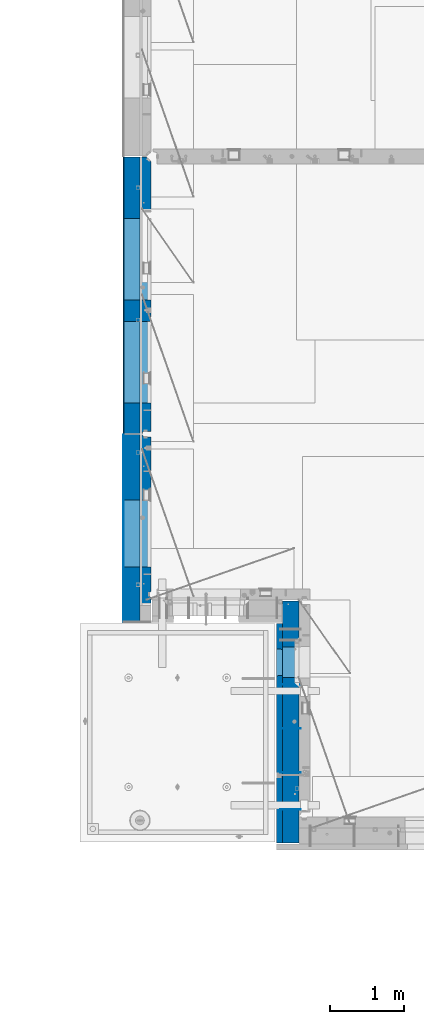
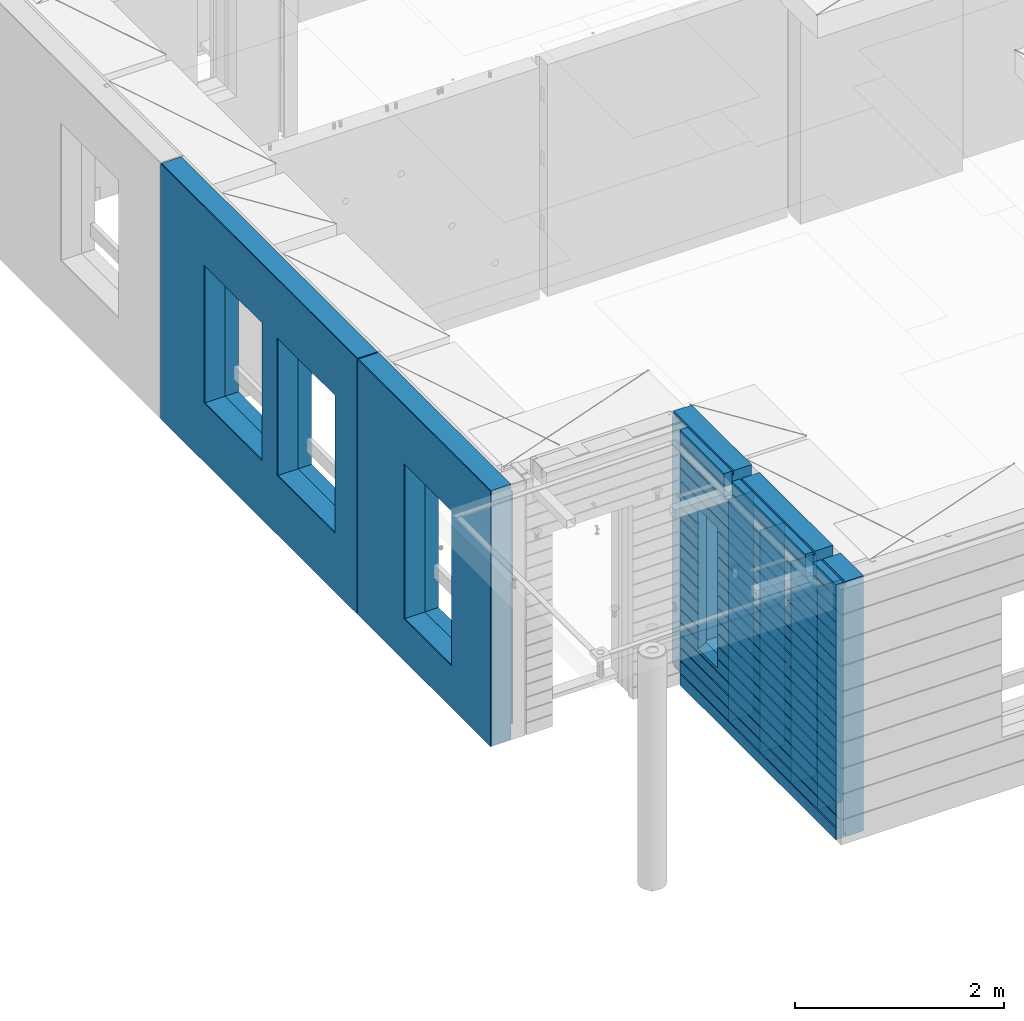
# One storey, part 228 of 350: 12 walls, 3 elements without a shape of their own.
"""IFC2X3 building model written with IfcOpenShell, lengths in millimetres."""

from ifc_helpers import new_model, si_unit, frame, origin_with_axes, place, context, subcontext, project, spatial, faceted_brep, material, type_object, element, aggregate, save


model = new_model("IFC2X3")

# Units and contexts
model_context = context("Model", 3, precision=1e-05, world=origin_with_axes())
body_context = subcontext(model_context, "Body", "Model", "MODEL_VIEW")
ifc_project = project(units=[si_unit("LENGTHUNIT", "METRE", prefix="MILLI"), si_unit("AREAUNIT", "SQUARE_METRE"), si_unit("VOLUMEUNIT", "CUBIC_METRE"), si_unit("MASSUNIT", "GRAM", prefix="KILO"), si_unit("TIMEUNIT", "SECOND"), si_unit("PLANEANGLEUNIT", "RADIAN"), si_unit("SOLIDANGLEUNIT", "STERADIAN"), si_unit("THERMODYNAMICTEMPERATUREUNIT", "DEGREE_CELSIUS"), si_unit("LUMINOUSINTENSITYUNIT", "LUMEN")], contexts=[model_context])

# Site, building, storey
site_placement = place(None, origin_with_axes())
site = spatial("IfcSite", under=ifc_project, at=site_placement, CompositionType="ELEMENT")
building_placement = place(site_placement, origin_with_axes())
building = spatial("IfcBuilding", under=site, at=building_placement, CompositionType="ELEMENT")
storey_placement = place(building_placement, origin_with_axes())
storey = spatial("IfcBuildingStorey", under=building, at=storey_placement, Name="2", CompositionType="ELEMENT", Elevation=0.0)

# Assembly, walls
assembly_1_placement = place(storey_placement, origin_with_axes())
assembly_1 = element("IfcElementAssembly", 1, at=assembly_1_placement, inside=storey, AssemblyPlace="NOTDEFINED", PredefinedType="REINFORCEMENT_UNIT")
ifc_material_1 = material(Name="Undefined")
wall_type_1 = type_object("IfcWallType", PredefinedType="NOTDEFINED")
wall_1_placement = place(assembly_1_placement, frame((10040.0, 8600.0, 86115.0), z_axis=(0.0, 0.0, 1.0), x_axis=(-1.0, 3.00000001838171e-08, 0.0)))
wall_1 = element("IfcWall", 2, at=wall_1_placement, type_object=wall_type_1, material=ifc_material_1, Name="(PD)", context=body_context, shape_type="Brep", body=[
    faceted_brep([(0.0, 5.0, -1300.0), (0.0, 5.0, 1300.0), (280.0, 5.0, 1300.0), (280.0, 5.0, -1300.0), (0.0, -5.0, 1300.0), (280.0, -5.0, 1300.0), (0.0, -5.0, -1300.0), (280.0, -5.0, -1300.0)], [[[0, 1, 2, 3]], [[1, 4, 5, 2]], [[4, 6, 7, 5]], [[6, 0, 3, 7]], [[5, 7, 3, 2]], [[6, 4, 1, 0]]]),
])
wall_2_placement = place(assembly_1_placement, frame((10040.0, 9200.0, 86115.0), z_axis=(0.0, 0.0, 1.0), x_axis=(-1.0, 3.00000001838171e-08, 0.0)))
wall_2 = element("IfcWall", 3, at=wall_2_placement, type_object=wall_type_1, material=ifc_material_1, Name="(PD)", context=body_context, shape_type="Brep", body=[
    faceted_brep([(0.0, 5.0, -1300.0), (0.0, 5.0, 1300.0), (280.0, 5.0, 1300.0), (280.0, 5.0, -1300.0), (0.0, -5.0, 1300.0), (280.0, -5.0, 1300.0), (0.0, -5.0, -1300.0), (280.0, -5.0, -1300.0)], [[[0, 1, 2, 3]], [[1, 4, 5, 2]], [[4, 6, 7, 5]], [[6, 0, 3, 7]], [[5, 7, 3, 2]], [[6, 4, 1, 0]]]),
])
wall_3_placement = place(assembly_1_placement, frame((10040.0, 8100.0, 86115.0), z_axis=(0.0, 0.0, 1.0), x_axis=(-1.0, 3.00000001838171e-08, 0.0)))
wall_3 = element("IfcWall", 4, at=wall_3_placement, type_object=wall_type_1, material=ifc_material_1, Name="(PD)", context=body_context, shape_type="Brep", body=[
    faceted_brep([(0.0, 5.0, -1300.0), (0.0, 5.0, 1300.0), (280.0, 5.0, 1300.0), (280.0, 5.0, -1300.0), (0.0, -5.0, 1300.0), (280.0, -5.0, 1300.0), (0.0, -5.0, -1300.0), (280.0, -5.0, -1300.0)], [[[0, 1, 2, 3]], [[1, 4, 5, 2]], [[4, 6, 7, 5]], [[6, 0, 3, 7]], [[5, 7, 3, 2]], [[6, 4, 1, 0]]]),
])
wall_4_placement = place(assembly_1_placement, frame((10040.0, 9800.0, 86115.0), z_axis=(0.0, 0.0, 1.0), x_axis=(-1.0, 3.00000001838171e-08, 0.0)))
wall_4 = element("IfcWall", 5, at=wall_4_placement, type_object=wall_type_1, material=ifc_material_1, Name="(PD)", context=body_context, shape_type="Brep", body=[
    faceted_brep([(0.0, 5.0, -1300.0), (0.0, 5.0, 1300.0), (280.0, 5.0, 1300.0), (280.0, 5.0, -1300.0), (0.0, -5.0, 1300.0), (280.0, -5.0, 1300.0), (0.0, -5.0, -1300.0), (280.0, -5.0, -1300.0)], [[[0, 1, 2, 3]], [[1, 4, 5, 2]], [[4, 6, 7, 5]], [[6, 0, 3, 7]], [[5, 7, 3, 2]], [[6, 4, 1, 0]]]),
])
ifc_material_2 = material(Name="COS5gt")
wall_type_2 = type_object("IfcWallType", PredefinedType="NOTDEFINED")
wall_5_placement = place(assembly_1_placement, frame((9900.0, 8000.0, 86247.5), z_axis=(0.0, 0.0, 1.0), x_axis=(0.0, 1.0, 0.0)))
wall_5 = element("IfcWall", 6, at=wall_5_placement, type_object=wall_type_2, material=ifc_material_2, context=body_context, shape_type="Brep", body=[
    faceted_brep([(2935.0, 90.0, 1492.5), (2935.0, 90.0, 1442.5), (1785.0, 90.0, 1442.5), (1785.0, 90.0, 1492.5), (2935.0, 110.0, 1442.5), (1785.0, 110.0, 1442.5), (1635.0, 90.0, 1442.5), (1635.0, 110.0, 1442.5), (229.999999999998, 110.0, 1442.5), (229.999999999998, 90.0, 1442.5), (1635.0, 90.0, 1492.5), (229.999999999998, 90.0, 1492.5), (1635.0, -110.0, 1492.5), (1635.0, -110.0, 1222.5), (1635.0, 110.0, 1222.5), (1785.0, -110.0, 1222.5), (1785.0, 110.0, 1222.5), (1785.0, -110.0, 1492.5), (2935.0, -110.0, 1492.5), (2935.0, -110.0, -1492.5), (-355.0, -110.0, -1492.5), (-355.0, 90.0, -1492.5), (2935.0, 90.0, -1492.5), (2935.0, 90.0, -1442.5), (2935.0, 110.0, -1442.5), (-355.0, 90.0, -1442.5), (-355.0, 110.0, -1442.5), (-355.0, -110.0, 1492.5), (-355.0, 90.0, 1492.5), (-355.0, 90.0, 1442.5), (-355.0, 110.0, 1442.5), (79.9999999999982, 90.0, 1442.5), (79.9999999999982, 110.0, 1442.5), (79.9999999999982, 110.0, 1222.5), (229.999999999998, 110.0, 1222.5), (1895.00042424099, 109.999999996904, -802.5), (1895.00042424099, 109.999999996904, -807.5), (1925.00042424099, 109.999999996904, -807.5), (2275.00042424099, 109.999999996904, -807.5), (2305.00042424099, 109.999999996904, -807.5), (2305.00042424099, 109.999999996904, -802.5), (2305.00042424099, 109.999999996904, 807.5), (1895.00042424099, 109.999999996904, 807.5), (1889.05447829513, -110.0, 813.445945945859), (2310.94637018685, -110.0, 813.445945945859), (1889.05447829513, -110.0, -813.445945945859), (2310.94637018685, -110.0, -813.445945945859), (79.9999999999982, -110.0, 1222.5), (79.9999999999982, -110.0, 1492.5), (229.999999999998, -110.0, 1492.5), (229.999999999998, -110.0, 1222.5), (79.9999999999982, 90.0, 1492.5)], [[[0, 1, 2, 3]], [[1, 4, 5, 2]], [[6, 7, 8, 9]], [[10, 6, 9, 11]], [[12, 13, 14, 7, 6, 10]], [[15, 16, 14, 13]], [[17, 3, 2, 5, 16, 15]], [[18, 0, 3, 17]], [[19, 20, 21, 22]], [[4, 1, 0, 18, 19, 22, 23, 24]], [[23, 25, 26, 24]], [[22, 21, 25, 23]], [[20, 27, 28, 29, 30, 26, 25, 21]], [[30, 29, 31, 32]], [[7, 14, 16, 5, 4, 24, 26, 30, 32, 33, 34, 8], [35, 36, 37, 38, 39, 40, 41, 42]], [[43, 42, 41, 44]], [[45, 36, 35, 42, 43]], [[46, 39, 38, 37, 36, 45]], [[44, 41, 40, 39, 46]], [[47, 48, 27, 20, 19, 18, 17, 15, 13, 12, 49, 50], [45, 43, 44, 46]], [[28, 27, 48, 51]], [[29, 28, 51, 31]], [[48, 47, 33, 32, 31, 51]], [[50, 34, 33, 47]], [[49, 11, 9, 8, 34, 50]], [[12, 10, 11, 49]]]),
])

# Assembly, wall
assembly_2_placement = place(storey_placement, origin_with_axes())
assembly_2 = element("IfcElementAssembly", 7, at=assembly_2_placement, inside=storey, AssemblyPlace="NOTDEFINED", PredefinedType="REINFORCEMENT_UNIT")
ifc_material_3 = material()
wall_6_placement = place(assembly_2_placement, frame((7739.99972588711, 13210.0004309454, 86247.5), z_axis=(0.0, 0.0, 1.0), x_axis=(0.0, 1.0, 0.0)))
wall_6 = element("IfcWall", 8, at=wall_6_placement, type_object=wall_type_2, material=ifc_material_3, context=body_context, shape_type="Brep", body=[
    faceted_brep([(0.0, 110.0, 1492.5), (0.0, -110.0, 1492.5), (3759.99957708461, -110.0, 1492.5), (3759.99956102462, 110.0, 1492.5), (0.0, -110.0, -1492.5), (0.0, 110.0, -1492.5), (3759.99956102462, 110.0, -1492.5), (3759.99957708461, -110.0, -1492.5), (414.999554466332, -110.0, -802.5), (414.999554466332, -110.0, 807.5), (1524.99955446633, -110.000000000001, 807.5), (1524.99955446633, -110.000000000001, -802.5), (1814.99999876569, -110.0, -802.5), (1814.99999876569, -110.0, 807.5), (2924.99999876569, -110.0, 807.5), (2924.99999876569, -110.0, -802.5), (1814.99999876569, 110.0, -802.5), (1814.99999876569, 110.0, 807.5), (2924.99999876569, 110.0, -802.5), (2924.99999876569, 110.0, 807.5), (414.999554466332, 110.0, -802.5), (1524.99955446633, 109.999999999999, -802.5), (1524.99955446633, 109.999999999999, 807.5), (414.999554466332, 110.0, 807.5)], [[[0, 1, 2, 3]], [[4, 1, 0, 5]], [[4, 5, 6, 7]], [[2, 7, 6, 3]], [[1, 4, 7, 2], [8, 9, 10, 11], [12, 13, 14, 15]], [[12, 16, 17, 13]], [[15, 18, 16, 12]], [[14, 19, 18, 15]], [[13, 17, 19, 14]], [[5, 0, 3, 6], [20, 21, 22, 23], [16, 18, 19, 17]], [[10, 22, 21, 11]], [[9, 23, 22, 10]], [[8, 20, 23, 9]], [[11, 21, 20, 8]]]),
])

assembly_3_placement = place(storey_placement, origin_with_axes())
assembly_3 = element("IfcElementAssembly", 9, at=assembly_3_placement, inside=storey, AssemblyPlace="NOTDEFINED", PredefinedType="REINFORCEMENT_UNIT")
wall_7_placement = place(assembly_3_placement, frame((7740.00002947772, 10874.9996836349, 86247.5), z_axis=(0.0, 0.0, 1.0), x_axis=(0.0, 1.0, 0.0)))
wall_7 = element("IfcWall", 10, at=wall_7_placement, type_object=wall_type_2, material=ifc_material_3, context=body_context, shape_type="Brep", body=[
    faceted_brep([(-219.99966922487, -110.0, 1492.5), (-219.99966922487, -110.0, -1492.5), (2320.00069431996, -110.000000000001, -1492.5), (2320.00069431996, -110.000000000001, 1492.5), (520.000578694053, -110.000000000001, -1002.5), (520.000578694053, -110.000000000001, 807.5), (1430.00057869405, -110.000000000001, 807.5), (1430.00057869405, -110.000000000001, -1002.5), (-219.99966922487, 110.0, 1492.5), (2320.00069431997, 110.0, 1492.5), (-219.99966922487, 110.0, -1492.5), (2320.00069431997, 110.0, -1492.5), (520.000578694055, 110.0, -1002.5), (1430.00057869406, 110.0, -1002.5), (1430.00057869406, 110.0, 807.5), (520.000578694055, 110.0, 807.5)], [[[0, 1, 2, 3], [4, 5, 6, 7]], [[8, 0, 3, 9]], [[1, 0, 8, 10]], [[1, 10, 11, 2]], [[3, 2, 11, 9]], [[10, 8, 9, 11], [12, 13, 14, 15]], [[6, 14, 13, 7]], [[5, 15, 14, 6]], [[4, 12, 15, 5]], [[7, 13, 12, 4]]]),
])

# Wall
ifc_material_4 = material(Name="CONCRETE/C30/37")
wall_type_3 = type_object("IfcWallType", PredefinedType="NOTDEFINED")
wall_8_placement = place(assembly_1_placement, frame((9747.5, 8000.0, 86247.5), z_axis=(0.0, 0.0, 1.0), x_axis=(0.0, 1.0, 0.0)))
wall_8 = element("IfcWall", 11, at=wall_8_placement, type_object=wall_type_3, material=ifc_material_4, context=body_context, shape_type="Brep", body=[
    faceted_brep([(-355.0, 32.4999992499324, 1344.99999999921), (-355.0, 32.4999991119385, 1355.00000040044), (79.9999999999982, 32.4999991119385, 1355.00000040044), (79.9999999999982, 32.4999992499324, 1344.99999999921), (-355.0, 42.5, 1342.99999994476), (79.9999999999982, 42.5, 1342.99999994476), (2630.0, 32.4999991119385, 1355.00000040044), (2630.0, 32.4999992499324, 1344.99999999921), (1785.0, 32.4999992499324, 1344.99999999921), (1785.0, 32.4999991119385, 1355.00000040044), (2630.0, 42.5, 1356.99999988925), (1785.0, 42.5, 1356.99999988925), (2630.0, 42.5, 1492.5), (1785.0, 42.5, 1492.5), (2630.0, -42.5, 1492.5), (1785.0, -42.5, 1492.5), (-355.0, -42.5, -1492.5), (-355.0, 42.5, -1492.5), (2630.0, 42.5, -1492.5), (2630.0, -42.5, -1492.5), (-355.0, 42.5, -1357.00000005524), (2630.0, 42.5, -1357.00000005524), (-355.0, 32.4999992506928, -1355.0000000008), (2630.0, 32.4999992506928, -1355.0000000008), (-355.0, 32.4999991126915, -1344.99999959957), (2630.0, 32.4999991126915, -1344.99999959957), (-355.0, 42.5, -1343.00000011075), (2630.0, 42.5, -1343.00000011075), (-355.0, 42.5, -1207.00000005524), (2630.0, 42.5, -1207.00000005524), (-355.0, 32.4999992506928, -1205.0000000008), (2630.0, 32.4999992506928, -1205.0000000008), (-355.0, 32.4999991126915, -1194.99999959957), (2630.0, 32.4999991126915, -1194.99999959957), (-355.0, 42.5, -1193.00000011075), (2630.0, 42.5, -1193.00000011075), (-355.0, 42.5, -1057.00000005525), (2630.0, 42.5, -1057.00000005525), (-355.0, 32.4999992512294, -1055.00000000081), (2630.0, 32.4999992512294, -1055.00000000081), (-355.0, 32.4999991132281, -1044.99999959959), (2630.0, 32.4999991132281, -1044.99999959959), (-355.0, 42.5, -1043.00000011077), (2630.0, 42.5, -1043.00000011077), (-355.0, 42.5, -907.000000055225), (2630.0, 42.5, -907.000000055225), (-355.000000000001, 32.4999992517678, -905.000000000786), (2630.0, 32.4999992517678, -905.000000000786), (-355.000000000001, 32.4999991137665, -894.99999959956), (2630.0, 32.4999991137665, -894.99999959956), (-355.0, 42.5, -893.00000011074), (2630.0, 42.5, -893.00000011074), (2630.0, 42.5, -307.000000055239), (2630.0, 32.4999992538942, -305.0000000008), (2630.0, 32.4999991158911, -294.999999599575), (2630.0, 42.5, -293.000000110755), (2630.0, 42.5, -157.000000055254), (2630.0, 32.4999992544235, -155.000000000815), (2630.0, 32.4999991164223, -144.99999959959), (2630.0, 42.5, -143.000000110769), (2630.0, 42.5, -7.00000005523907), (2630.0, 32.4999992500489, -5.0000000007858), (2630.0, 32.4999991120549, 5.0000004004396), (2630.0, 42.5, 6.99999988924537), (2630.0, 42.5, 142.999999944761), (2630.0, 32.4999992500361, 144.999999999214), (2630.0, 32.4999991120421, 155.00000040044), (2630.0, 42.5, 156.999999889245), (2630.0, 42.5, 292.999999944761), (2630.0, 32.4999992500234, 294.999999999214), (2630.0, 32.4999991120294, 305.00000040044), (2630.0, 42.5, 306.999999889245), (2630.0, 42.5, 442.999999944761), (2630.0, 32.4999992500107, 444.999999999214), (2630.0, 32.4999991120167, 455.00000040044), (2630.0, 42.5, 456.999999889245), (2630.0, 42.5, 592.999999944761), (2630.0, 32.4999992499979, 594.999999999214), (2630.0, 32.4999991120039, 605.00000040044), (2630.0, 42.5, 606.999999889245), (2630.0, 42.5, 742.999999944761), (2630.0, 32.4999992499852, 744.999999999214), (2630.0, 32.4999991119912, 755.00000040044), (2630.0, 42.5, 756.999999889245), (2630.0, 42.5, 892.999999944761), (2630.0, 32.4999992499725, 894.999999999214), (2630.0, 32.4999991119785, 905.00000040044), (2630.0, 42.5, 906.999999889245), (2630.0, 42.5, 1042.99999994476), (2630.0, 32.4999992499597, 1044.99999999921), (2630.0, 32.4999991119657, 1055.00000040044), (2630.0, 42.5, 1056.99999988925), (2630.0, 42.5, 1192.99999994476), (2630.0, 32.499999249947, 1194.99999999921), (2630.0, 32.499999111953, 1205.00000040044), (2630.0, 42.5, 1206.99999988925), (2630.0, 42.5, 1342.99999994476), (2630.0, 42.5, -757.000000055225), (2630.0, 32.4999992522953, -755.000000000786), (2630.0, 32.499999114294, -744.99999959956), (2630.0, 42.5, -743.00000011074), (2630.0, 42.5, -607.000000055225), (2630.0, 32.4999992522953, -605.000000000786), (2630.0, 32.499999114294, -594.99999959956), (2630.0, 42.5, -593.00000011074), (2630.0, 42.5, -457.000000055225), (2630.0, 32.4999992522953, -455.000000000786), (2630.0, 32.499999114294, -444.99999959956), (2630.0, 42.5, -443.00000011074), (1785.0, 42.5, 1342.99999994476), (1785.0, 42.5, 1222.5), (1785.0, -42.5, 1222.5), (1635.0, 42.5, 1222.5), (1635.0, -42.5, 1222.5), (1635.0, -42.5, 1492.5), (1635.0, 42.5, 1492.5), (229.999999999998, 42.5, 1492.5), (229.999999999998, -42.5, 1492.5), (1635.0, 32.4999991119385, 1355.00000040044), (1635.0, 32.4999992499324, 1344.99999999921), (229.999999999998, 32.4999992499324, 1344.99999999921), (229.999999999998, 32.4999991119385, 1355.00000040044), (1635.0, 42.5, 1356.99999988925), (229.999999999998, 42.5, 1356.99999988925), (1635.0, 42.5, 1342.99999994476), (229.999999999998, 42.5, 1342.99999994476), (229.999999999998, -42.5, 1222.5), (229.999999999998, 42.5, 1222.5), (79.9999999999982, 42.5, 1222.5), (79.9999999999982, -42.5, 1222.5), (-355.0, 42.5, 1206.99999988925), (-355.0, 32.499999111953, 1205.00000040044), (-355.0, 32.499999249947, 1194.99999999921), (-355.0, 42.5, 1192.99999994476), (-355.0, 42.5, 1056.99999988925), (-355.0, 32.4999991119657, 1055.00000040044), (-355.0, 32.4999992499597, 1044.99999999921), (-355.0, 42.5, 1042.99999994476), (-355.0, 42.5, 906.999999889245), (-354.999999999999, 32.4999991119785, 905.00000040044), (-354.999999999999, 32.4999992499725, 894.999999999214), (-355.0, 42.5, 892.999999944761), (-355.0, 42.5, -457.000000055225), (-355.0, 42.5, -593.00000011074), (-354.999999999998, 32.499999114294, -594.99999959956), (-354.999999999998, 32.4999992522953, -605.000000000786), (-355.0, 42.5, -607.000000055225), (-355.0, 42.5, -743.00000011074), (-355.0, 32.499999114294, -744.99999959956), (-355.0, 32.4999992522953, -755.000000000786), (-355.0, 42.5, -757.000000055225), (-355.0, -42.5, 1492.5), (-355.0, 42.5, 1492.5), (-355.0, 42.5, 1356.99999988925), (-355.0, 42.5, 756.999999889245), (-354.999999999999, 32.4999991119912, 755.00000040044), (-354.999999999999, 32.4999992499852, 744.999999999214), (-355.0, 42.5, 742.999999944761), (-355.0, 42.5, 606.999999889245), (-355.0, 32.4999991120039, 605.00000040044), (-355.0, 32.4999992499979, 594.999999999214), (-355.0, 42.5, 592.999999944761), (-355.0, 42.5, 456.999999889245), (-355.0, 32.4999991120167, 455.00000040044), (-355.0, 32.4999992500107, 444.999999999214), (-355.0, 42.5, 442.999999944761), (-355.0, 42.5, 306.999999889245), (-355.0, 32.4999991120294, 305.00000040044), (-355.0, 32.4999992500234, 294.999999999214), (-355.0, 42.5, 292.999999944761), (-355.0, 42.5, 156.999999889245), (-355.0, 32.4999991120421, 155.00000040044), (-355.0, 32.4999992500361, 144.999999999214), (-355.0, 42.5, 142.999999944761), (-355.0, 42.5, 6.99999988924537), (-355.0, 32.4999991120549, 5.0000004004396), (-355.0, 32.4999992500489, -5.0000000007858), (-355.0, 42.5, -7.00000005523907), (-355.0, 42.5, -143.000000110769), (-354.999999999999, 32.4999991164223, -144.99999959959), (-354.999999999999, 32.4999992544235, -155.000000000815), (-355.0, 42.5, -157.000000055254), (-355.0, 42.5, -293.000000110755), (-355.0, 32.4999991158911, -294.999999599575), (-355.0, 32.4999992538942, -305.0000000008), (-355.0, 42.5, -307.000000055239), (-355.0, 42.5, -443.00000011074), (-355.000000000001, 32.499999114294, -444.99999959956), (-355.000000000001, 32.4999992522953, -455.000000000786), (1915.00042424099, 42.5, 756.999999889245), (1916.1768949337, 32.4999991119912, 755.00000040044), (1916.17689491746, 32.4999992499852, 744.999999999214), (1915.00042424099, 42.5, 742.999999944761), (1915.00042424099, 42.5, 606.999999889245), (1916.17689493369, 32.4999991120039, 605.00000040044), (1916.17689491746, 32.4999992499979, 594.999999999214), (1915.00042424099, 42.5, 592.999999944761), (1915.00042424099, 42.5, 456.999999889245), (1916.17689493369, 32.4999991120167, 455.00000040044), (1916.17689491746, 32.4999992500107, 444.999999999214), (1915.00042424099, 42.5, 442.999999944761), (1915.00042424099, 42.5, 306.999999889245), (1916.17689493369, 32.4999991120294, 305.00000040044), (1916.17689491746, 32.4999992500234, 294.999999999214), (1915.00042424099, 42.5, 292.999999944761), (1915.00042424099, 42.5, 156.999999889245), (1916.17689493369, 32.4999991120421, 155.00000040044), (1916.17689491745, 32.4999992500361, 144.999999999214), (1915.00042424099, 42.5, 142.999999944761), (1915.00042424099, 42.5, 6.99999988924537), (1916.17689493369, 32.4999991120549, 5.0000004004396), (1916.17689491745, 32.4999992500489, -5.0000000007858), (1915.00042424099, 42.5, -7.00000005523907), (1915.00042424099, 42.5, -143.000000110769), (1916.17689493317, 32.4999991164223, -144.99999959959), (1916.17689491694, 32.4999992544235, -155.000000000815), (1915.00042424099, 42.5, -157.000000055254), (1915.00042424099, 42.5, -293.000000110755), (1916.17689493324, 32.4999991158911, -294.999999599575), (1916.176894917, 32.4999992538942, -305.0000000008), (1915.00042424099, 42.5, -307.000000055239), (1915.00042424099, 42.5, -443.00000011074), (1916.17689493342, 32.499999114294, -444.99999959956), (1916.17689491719, 32.4999992522953, -455.000000000786), (1915.00042424099, 42.5, -457.000000055225), (1915.00042424099, 42.5, -593.00000011074), (1916.17689493343, 32.499999114294, -594.99999959956), (1916.17689491719, 32.4999992522953, -605.000000000786), (1915.00042424099, 42.5, -607.000000055225), (1915.00042424099, 42.5, -743.00000011074), (1916.17689493343, 32.499999114294, -744.99999959956), (1916.17689491719, 32.4999992522953, -755.000000000786), (1915.00042424099, 42.5, -757.000000055225), (1915.00042424099, 42.5, -857.5), (2285.00042424099, 42.5, -857.5), (2285.00042424099, 42.5, -757.000000055225), (2283.82395356479, 32.4999992522953, -755.000000000786), (2283.82395354855, 32.499999114294, -744.99999959956), (2285.00042424099, 42.5, -743.00000011074), (2285.00042424099, 42.5, -607.000000055225), (2283.82395356479, 32.4999992522953, -605.000000000786), (2283.82395354855, 32.499999114294, -594.99999959956), (2285.00042424099, 42.5, -593.00000011074), (2285.00042424099, 42.5, -457.000000055225), (2283.82395356479, 32.4999992522953, -455.000000000786), (2283.82395354855, 32.499999114294, -444.99999959956), (2285.00042424099, 42.5, -443.00000011074), (2285.00042424099, 42.5, -307.000000055239), (2283.82395356498, 32.4999992538942, -305.0000000008), (2283.82395354874, 32.4999991158911, -294.999999599575), (2285.00042424099, 42.5, -293.000000110755), (2285.00042424099, 42.5, -157.000000055254), (2283.82395356504, 32.4999992544235, -155.000000000815), (2283.8239535488, 32.4999991164223, -144.99999959959), (2285.00042424099, 42.5, -143.000000110769), (2285.00042424099, 42.5, -7.00000005523907), (2283.82395356452, 32.4999992500489, -5.0000000007858), (2283.82395354829, 32.4999991120549, 5.0000004004396), (2285.00042424099, 42.5, 6.99999988924537), (2285.00042424099, 42.5, 142.999999944761), (2283.82395356452, 32.4999992500361, 144.999999999214), (2283.82395354829, 32.4999991120421, 155.00000040044), (2285.00042424099, 42.5, 156.999999889245), (2285.00042424099, 42.5, 292.999999944761), (2283.82395356452, 32.4999992500234, 294.999999999214), (2283.82395354829, 32.4999991120294, 305.00000040044), (2285.00042424099, 42.5, 306.999999889245), (2285.00042424099, 42.5, 442.999999944761), (2283.82395356452, 32.4999992500107, 444.999999999214), (2283.82395354828, 32.4999991120167, 455.00000040044), (2285.00042424099, 42.5, 456.999999889245), (2285.00042424099, 42.5, 592.999999944761), (2283.82395356452, 32.4999992499979, 594.999999999214), (2283.82395354828, 32.4999991120039, 605.00000040044), (2285.00042424099, 42.5, 606.999999889245), (2285.00042424099, 42.5, 742.999999944761), (2283.82395356452, 32.4999992499852, 744.999999999214), (2283.82395354828, 32.4999991119912, 755.00000040044), (2285.00042424099, 42.5, 756.999999889245), (1925.00042424099, 42.5, 782.5), (1915.00042424099, 42.5, 782.5), (2285.00042424099, 42.5, 782.5), (2275.00042424099, 42.5, 782.5), (1925.00042424099, -42.5, 787.5), (2275.00042424099, -42.5, 787.5), (1925.00042424099, -42.5, 782.5), (1925.00042424099, -42.5, -807.5), (2275.00042424099, -42.5, -807.5), (2275.00042424099, -42.5, 782.5), (79.9999999999982, -42.5, 1492.5), (79.9999999999982, 42.5, 1492.5), (79.9999999999982, 42.5, 1356.99999988925)], [[[0, 1, 2, 3]], [[4, 0, 3, 5]], [[6, 7, 8, 9]], [[10, 6, 9, 11]], [[12, 10, 11, 13]], [[14, 12, 13, 15]], [[16, 17, 18, 19]], [[18, 17, 20, 21]], [[21, 20, 22, 23]], [[23, 22, 24, 25]], [[25, 24, 26, 27]], [[28, 29, 27, 26]], [[29, 28, 30, 31]], [[31, 30, 32, 33]], [[33, 32, 34, 35]], [[35, 34, 36, 37]], [[37, 36, 38, 39]], [[39, 38, 40, 41]], [[41, 40, 42, 43]], [[43, 42, 44, 45]], [[45, 44, 46, 47]], [[47, 46, 48, 49]], [[49, 48, 50, 51]], [[52, 53, 54, 55, 56, 57, 58, 59, 60, 61, 62, 63, 64, 65, 66, 67, 68, 69, 70, 71, 72, 73, 74, 75, 76, 77, 78, 79, 80, 81, 82, 83, 84, 85, 86, 87, 88, 89, 90, 91, 92, 93, 94, 95, 96, 7, 6, 10, 12, 14, 19, 18, 21, 23, 25, 27, 29, 31, 33, 35, 37, 39, 41, 43, 45, 47, 49, 51, 97, 98, 99, 100, 101, 102, 103, 104, 105, 106, 107, 108]], [[7, 96, 109, 8]], [[15, 13, 11, 9, 8, 109, 110, 111]], [[111, 110, 112, 113]], [[114, 115, 116, 117]], [[118, 119, 120, 121]], [[122, 118, 121, 123]], [[115, 122, 123, 116]], [[114, 113, 112, 124, 119, 118, 122, 115]], [[119, 124, 125, 120]], [[126, 127, 128, 129]], [[117, 116, 123, 121, 120, 125, 127, 126]], [[124, 112, 110, 109, 96, 95, 130, 4, 5, 128, 127, 125]], [[94, 131, 130, 95]], [[93, 132, 131, 94]], [[92, 133, 132, 93]], [[91, 134, 133, 92]], [[90, 135, 134, 91]], [[89, 136, 135, 90]], [[88, 137, 136, 89]], [[87, 138, 137, 88]], [[86, 139, 138, 87]], [[85, 140, 139, 86]], [[84, 141, 140, 85]], [[142, 143, 144, 145, 146, 147, 148, 149, 150, 50, 48, 46, 44, 42, 40, 38, 36, 34, 32, 30, 28, 26, 24, 22, 20, 17, 16, 151, 152, 153, 1, 0, 4, 130, 131, 132, 133, 134, 135, 136, 137, 138, 139, 140, 141, 154, 155, 156, 157, 158, 159, 160, 161, 162, 163, 164, 165, 166, 167, 168, 169, 170, 171, 172, 173, 174, 175, 176, 177, 178, 179, 180, 181, 182, 183, 184, 185, 186, 187, 188]], [[155, 154, 189, 190]], [[156, 155, 190, 191]], [[157, 156, 191, 192]], [[158, 157, 192, 193]], [[159, 158, 193, 194]], [[160, 159, 194, 195]], [[161, 160, 195, 196]], [[162, 161, 196, 197]], [[163, 162, 197, 198]], [[164, 163, 198, 199]], [[165, 164, 199, 200]], [[166, 165, 200, 201]], [[167, 166, 201, 202]], [[168, 167, 202, 203]], [[169, 168, 203, 204]], [[170, 169, 204, 205]], [[171, 170, 205, 206]], [[172, 171, 206, 207]], [[173, 172, 207, 208]], [[174, 173, 208, 209]], [[175, 174, 209, 210]], [[176, 175, 210, 211]], [[177, 176, 211, 212]], [[178, 177, 212, 213]], [[179, 178, 213, 214]], [[180, 179, 214, 215]], [[181, 180, 215, 216]], [[182, 181, 216, 217]], [[183, 182, 217, 218]], [[184, 183, 218, 219]], [[185, 184, 219, 220]], [[186, 185, 220, 221]], [[187, 186, 221, 222]], [[188, 187, 222, 223]], [[142, 188, 223, 224]], [[143, 142, 224, 225]], [[144, 143, 225, 226]], [[145, 144, 226, 227]], [[146, 145, 227, 228]], [[147, 146, 228, 229]], [[148, 147, 229, 230]], [[149, 148, 230, 231]], [[150, 149, 231, 232]], [[97, 51, 50, 150, 232, 233, 234, 235]], [[98, 97, 235, 236]], [[99, 98, 236, 237]], [[100, 99, 237, 238]], [[101, 100, 238, 239]], [[102, 101, 239, 240]], [[103, 102, 240, 241]], [[104, 103, 241, 242]], [[105, 104, 242, 243]], [[106, 105, 243, 244]], [[107, 106, 244, 245]], [[108, 107, 245, 246]], [[52, 108, 246, 247]], [[53, 52, 247, 248]], [[54, 53, 248, 249]], [[55, 54, 249, 250]], [[56, 55, 250, 251]], [[57, 56, 251, 252]], [[58, 57, 252, 253]], [[59, 58, 253, 254]], [[60, 59, 254, 255]], [[61, 60, 255, 256]], [[62, 61, 256, 257]], [[63, 62, 257, 258]], [[64, 63, 258, 259]], [[65, 64, 259, 260]], [[66, 65, 260, 261]], [[67, 66, 261, 262]], [[68, 67, 262, 263]], [[69, 68, 263, 264]], [[70, 69, 264, 265]], [[71, 70, 265, 266]], [[72, 71, 266, 267]], [[73, 72, 267, 268]], [[74, 73, 268, 269]], [[75, 74, 269, 270]], [[76, 75, 270, 271]], [[77, 76, 271, 272]], [[78, 77, 272, 273]], [[79, 78, 273, 274]], [[80, 79, 274, 275]], [[81, 80, 275, 276]], [[82, 81, 276, 277]], [[83, 82, 277, 278]], [[279, 280, 189, 154, 141, 84, 83, 278, 281, 282]], [[283, 280, 279, 282, 281, 284]], [[285, 286, 233, 232, 231, 230, 229, 228, 227, 226, 225, 224, 223, 222, 221, 220, 219, 218, 217, 216, 215, 214, 213, 212, 211, 210, 209, 208, 207, 206, 205, 204, 203, 202, 201, 200, 199, 198, 197, 196, 195, 194, 193, 192, 191, 190, 189, 280, 283]], [[287, 234, 233, 286]], [[288, 284, 281, 278, 277, 276, 275, 274, 273, 272, 271, 270, 269, 268, 267, 266, 265, 264, 263, 262, 261, 260, 259, 258, 257, 256, 255, 254, 253, 252, 251, 250, 249, 248, 247, 246, 245, 244, 243, 242, 241, 240, 239, 238, 237, 236, 235, 234, 287]], [[129, 289, 151, 16, 19, 14, 15, 111, 113, 114, 117, 126], [287, 286, 285, 283, 284, 288]], [[152, 151, 289, 290]], [[153, 152, 290, 291]], [[289, 129, 128, 5, 3, 2, 291, 290]], [[1, 153, 291, 2]]]),
])

aggregate(assembly_1, [wall_1, wall_2, wall_3, wall_4, wall_5, wall_8])

ifc_material_5 = material(Name="CONCRETE/C25/30")
wall_type_4 = type_object("IfcWallType", PredefinedType="NOTDEFINED")
wall_9_placement = place(assembly_2_placement, frame((7924.9997258893, 13210.0004174404, 86112.5), z_axis=(0.0, 0.0, 1.0), x_axis=(0.0, 1.0, 0.0)))
wall_9 = element("IfcWall", 12, at=wall_9_placement, type_object=wall_type_4, material=ifc_material_5, context=body_context, shape_type="Brep", body=[
    faceted_brep([(1524.99955451006, -75.0000000617138, -667.5), (1524.99955451006, 75.0, -667.5), (414.999554510065, 75.0, -667.5), (414.999554510063, -75.000000114278, -667.5), (414.999554510065, 75.0, 942.5), (414.999554510063, -75.0000002207053, 942.5), (1524.99955451006, 75.0, 942.5), (1524.99955451006, -75.000000168141, 942.5), (0.0, 45.0, 1357.5), (0.0, 45.0, -1357.5), (29.9999989126591, 32.0000004547946, -1357.5), (29.9999989126591, 32.0000004547946, 1357.5), (0.0, 75.0, 1357.5), (0.0, 75.0, -1357.5), (3759.99957708464, 74.9999999999991, -1357.5), (3759.99957708464, 74.9999999999991, 1357.5), (3759.99958365464, -14.9999989005837, 1357.5), (3759.99958365464, -14.9999989005837, -1357.5), (30.0000016637459, -75.0, -1357.5), (3699.99959131522, -75.0000000000018, -1357.5), (30.0000016637459, -75.0, 1357.5), (3699.99959130954, -75.0000000056843, 1357.5), (1814.99999880942, -75.0000000486807, -667.5), (1814.99999880942, -75.0000001534236, 942.5), (2924.99999880942, -75.0000001008593, 942.5), (2924.99999880942, -74.9999999961165, -667.5), (1814.99999880942, 74.9999999999991, -667.5), (1814.99999880942, 74.9999999999991, 942.5), (2924.99999880942, 74.9999999999991, -667.5), (2924.99999880942, 74.9999999999991, 942.5)], [[[0, 1, 2, 3]], [[3, 2, 4, 5]], [[5, 4, 6, 7]], [[7, 6, 1, 0]], [[8, 9, 10, 11]], [[12, 13, 9, 8]], [[14, 15, 16, 17]], [[18, 10, 9, 13, 14, 17, 19]], [[11, 10, 18, 20]], [[15, 12, 8, 11, 20, 21, 16]], [[17, 16, 21, 19]], [[20, 18, 19, 21], [3, 5, 7, 0], [22, 23, 24, 25]], [[22, 26, 27, 23]], [[25, 28, 26, 22]], [[24, 29, 28, 25]], [[23, 27, 29, 24]], [[13, 12, 15, 14], [2, 1, 6, 4], [26, 28, 29, 27]]]),
])

wall_10_placement = place(assembly_3_placement, frame((7924.99999901751, 11107.4999902026, 86112.5), z_axis=(0.0, 0.0, 1.0), x_axis=(0.0, 1.0, 0.0)))
wall_10 = element("IfcWall", 13, at=wall_10_placement, type_object=wall_type_4, material=ifc_material_5, context=body_context, shape_type="Brep", body=[
    faceted_brep([(1197.50029630646, -74.9999998966041, -867.5), (1197.50029630646, 74.9999999999982, -867.5), (287.500296306462, 74.9999999999991, -867.5), (287.500296306462, -74.9999993964047, -867.5), (287.500296306462, 74.9999999999991, 942.5), (287.500296306462, -74.9999986286903, 942.5), (1197.50029630646, 74.9999999999982, 942.5), (1197.50029630646, -74.9999991288896, 942.5), (2087.5004119875, 44.9999999972642, 1357.5), (2087.5004119875, 74.9999999999991, 1357.5), (-232.500282332605, 74.9999999999991, 1357.5), (-232.500282332603, -75.0000000000009, 1357.5), (-122.50000002761, -75.0000000000009, 1357.5), (-109.499996997054, -54.9999860283524, 1357.5), (-55.4999970925001, -54.9999931295279, 1357.5), (-42.4999972430833, -74.9999976941244, 1357.5), (2057.50041198727, -75.0000000027349, 1357.5), (2057.50041198727, 24.9999999972651, 1357.5), (-232.500282332603, -75.0000000000009, -1357.5), (-232.500282332605, 74.9999999999991, -1357.5), (-122.50000002761, -75.0000000000009, -1357.5), (-109.499996997054, -54.9999860283524, -1357.5), (-55.4999970925001, -54.9999931295279, -1357.5), (-42.4999972430851, -75.0000000000009, -1357.5), (2057.50041198727, -75.0000000000009, -1357.5), (2057.50041198727, 24.9999999972651, -1357.5), (2087.5004119875, 74.9999999999991, -1357.5), (2087.5004119875, 44.9999999972642, -1357.5)], [[[0, 1, 2, 3]], [[3, 2, 4, 5]], [[5, 4, 6, 7]], [[7, 6, 1, 0]], [[8, 9, 10, 11, 12, 13, 14, 15, 16, 17]], [[18, 11, 10, 19]], [[11, 18, 20, 12]], [[12, 20, 21, 13]], [[13, 21, 22, 14]], [[15, 14, 22, 23]], [[15, 23, 24, 16], [3, 5, 7, 0]], [[16, 24, 25, 17]], [[23, 22, 21, 20, 18, 19, 26, 27, 25, 24]], [[17, 25, 27, 8]], [[26, 9, 8, 27]], [[19, 10, 9, 26], [2, 1, 6, 4]]]),
])

wall_type_5 = type_object("IfcWallType", PredefinedType="NOTDEFINED")
wall_11_placement = place(assembly_2_placement, frame((7624.9997258871, 13210.0004393404, 86247.5), z_axis=(0.0, 0.0, 1.0), x_axis=(0.0, 1.0, 0.0)))
wall_11 = element("IfcWall", 14, at=wall_11_placement, type_object=wall_type_5, material=ifc_material_4, context=body_context, shape_type="Brep", body=[
    faceted_brep([(0.0, 5.0, 1492.5), (0.0, -5.0, 1492.5), (3759.99956102465, -5.00000000000091, 1492.5), (3759.99956029465, 4.99999999999909, 1492.5), (0.0, -5.0, -1492.5), (0.0, 5.0, -1492.5), (3759.99956029465, 4.99999999999909, -1492.5), (3759.99956102465, -5.00000000000091, -1492.5), (414.999554402322, -5.00000000000091, -802.5), (414.999554402322, -5.00000000000091, 807.5), (1524.99955440232, -5.00000000000182, 807.5), (1524.99955440232, -5.00000000000182, -802.5), (1814.99999870163, -5.00000000000091, -802.5), (1814.99999870163, -5.00000000000091, 807.5), (2924.99999870163, -5.00000000000091, 807.5), (2924.99999870163, -5.00000000000091, -802.5), (1814.99999870163, 4.99999999999909, -802.5), (1814.99999870163, 4.99999999999909, 807.5), (2924.99999870163, 4.99999999999909, -802.5), (2924.99999870163, 4.99999999999909, 807.5), (414.999554402326, 4.99999999999818, -802.5), (1524.99955440232, 4.99999999999818, -802.5), (1524.99955440232, 4.99999999999818, 807.5), (414.999554402326, 4.99999999999818, 807.5)], [[[0, 1, 2, 3]], [[4, 1, 0, 5]], [[4, 5, 6, 7]], [[2, 7, 6, 3]], [[1, 4, 7, 2], [8, 9, 10, 11], [12, 13, 14, 15]], [[12, 16, 17, 13]], [[15, 18, 16, 12]], [[14, 19, 18, 15]], [[13, 17, 19, 14]], [[5, 0, 3, 6], [20, 21, 22, 23], [16, 18, 19, 17]], [[10, 22, 21, 11]], [[9, 23, 22, 10]], [[8, 20, 23, 9]], [[11, 21, 20, 8]]]),
])

aggregate(assembly_2, [wall_11, wall_6, wall_9])

wall_12_placement = place(assembly_3_placement, frame((7625.00002947765, 10874.99966857, 86247.5), z_axis=(0.0, 0.0, 1.0), x_axis=(0.0, 1.0, 0.0)))
wall_12 = element("IfcWall", 15, at=wall_12_placement, type_object=wall_type_5, material=ifc_material_4, context=body_context, shape_type="Brep", body=[
    faceted_brep([(-230.0, -5.0, 1492.5), (-230.0, -5.0, -1492.5), (2320.00069431993, -5.0, -1492.5), (2320.00069431993, -5.0, 1492.5), (520.000578774374, -5.0, -1002.5), (520.000578774374, -5.0, 807.5), (1430.00057877438, -5.0, 807.5), (1430.00057877438, -5.0, -1002.5), (-230.0, 5.0, 1492.5), (2320.00069431993, 5.0, 1492.5), (-230.0, 5.0, -1492.5), (2320.00069431993, 5.0, -1492.5), (520.000578774374, 5.0, -1002.5), (1430.00057877438, 5.0, -1002.5), (1430.00057877438, 5.0, 807.5), (520.000578774374, 5.0, 807.5)], [[[0, 1, 2, 3], [4, 5, 6, 7]], [[8, 0, 3, 9]], [[1, 0, 8, 10]], [[1, 10, 11, 2]], [[3, 2, 11, 9]], [[10, 8, 9, 11], [12, 13, 14, 15]], [[6, 14, 13, 7]], [[5, 15, 14, 6]], [[4, 12, 15, 5]], [[7, 13, 12, 4]]]),
])

aggregate(assembly_3, [wall_12, wall_7, wall_10])

save(model, "model.ifc")
